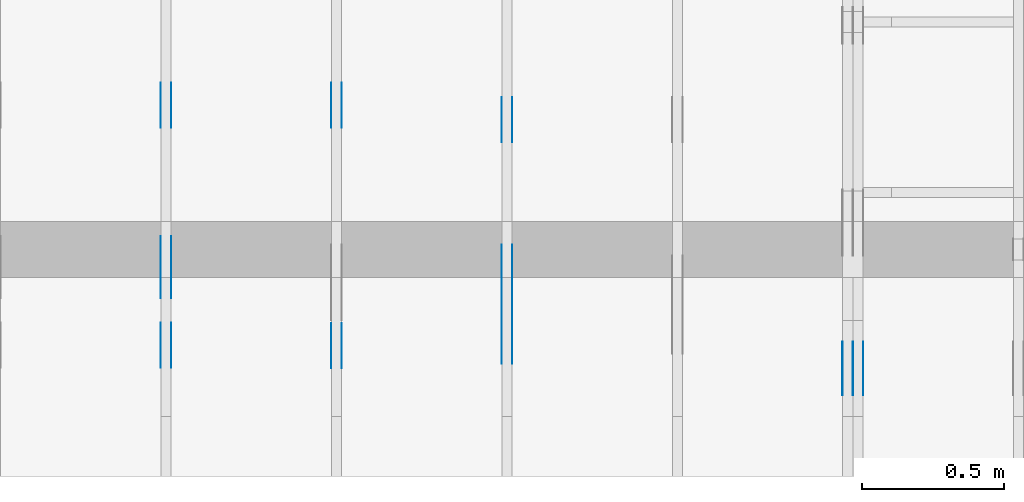
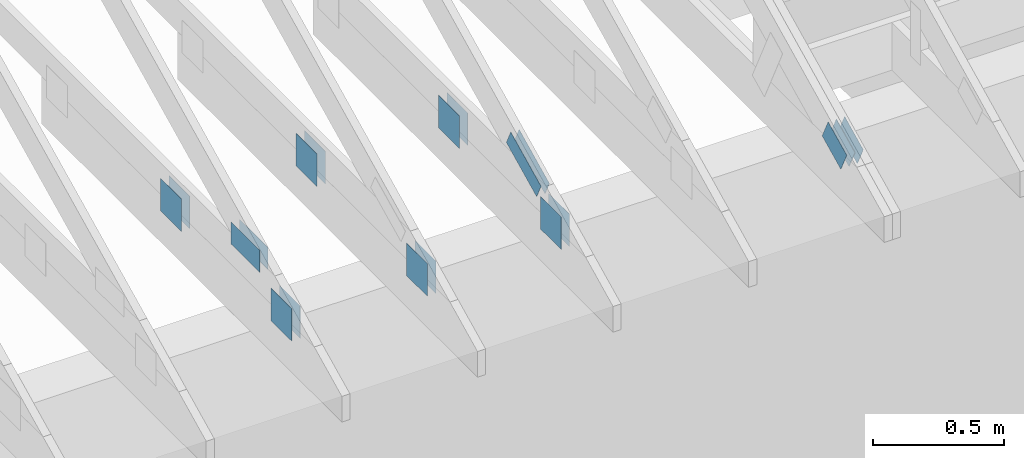
# One storey, part 112 of 159: 20 plates, 4 elements without a shape of their own.
"""IFC2X3 building model written with IfcOpenShell, lengths in millimetres."""

from ifc_helpers import new_model, si_unit, frame, origin, origin_with_axes, origin_2d, place, context, project, spatial, faceted_brep, element, aggregate, save


model = new_model("IFC2X3")

# Units and contexts
model_context = context("Model", 3, precision=1e-05, world=origin())
plan_context = context("Plan", 2, precision=1e-05, world=origin_2d())
ifc_project = project(units=[si_unit("LENGTHUNIT", "METRE", prefix="MILLI"), si_unit("AREAUNIT", "SQUARE_METRE"), si_unit("VOLUMEUNIT", "CUBIC_METRE"), si_unit("SOLIDANGLEUNIT", "STERADIAN"), si_unit("PLANEANGLEUNIT", "RADIAN"), si_unit("MASSUNIT", "GRAM"), si_unit("TIMEUNIT", "SECOND"), si_unit("THERMODYNAMICTEMPERATUREUNIT", "DEGREE_CELSIUS"), si_unit("LUMINOUSINTENSITYUNIT", "LUMEN")], contexts=[model_context, plan_context])

# Site, building, storey
site_placement = place(None, origin_with_axes())
site = spatial("IfcSite", under=ifc_project, at=site_placement, CompositionType="ELEMENT")
building_placement = place(site_placement, origin_with_axes())
building = spatial("IfcBuilding", under=site, at=building_placement, Name="Plan 1", CompositionType="ELEMENT")
storey_placement = place(building_placement, origin_with_axes())
storey = spatial("IfcBuildingStorey", under=building, at=storey_placement, Name="Etasje 1", CompositionType="ELEMENT", Elevation=0.0)

# Assembly, plates
assembly_1_placement = place(storey_placement, frame((16311.022261404749, -699.9989301294839, 1.1021457184401395e-15), z_axis=(1.0, -6.123031769111886e-17, 6.123031769111886e-17), x_axis=(6.123031769111886e-17, 1.0, 0.0)))
assembly_1 = element("IfcElementAssembly", 1, at=assembly_1_placement, inside=storey, Name="V8 (33)", AssemblyPlace="FACTORY", PredefinedType="TRUSS")
plate_1_placement = place(assembly_1_placement, frame((1227.8512822964763, 147.0, 0.0), z_axis=(0.0, 0.0, 1.0), x_axis=(1.0, 0.0, 0.0)))
plate_1 = element("IfcPlate", 2, at=plate_1_placement, Name="GNT100S 152x159", context=model_context, shape_type="Brep", body=[
    faceted_brep([(159.00003606289874, 152.0, 1.0), (3.606289874369395e-05, 152.0, 1.0), (3.606289874369395e-05, 0.0, 1.0), (159.00003606289874, 0.0, 1.0), (3.606289874369395e-05, 152.0, 4.416285493878064e-21), (159.00003606289874, 152.0, 1.947124544206129e-14), (159.00003606289874, 0.0, 1.947124544206129e-14), (3.606289874369395e-05, 0.0, 4.416285493878064e-21), (159.0, 8.234444213734565e-13, 1.788345410772899e-30), (159.0, 8.235056516911476e-13, 1.0), (1.1247455413666031e-32, 8.527125132298113e-13, 1.0), (0.0, 8.526512829121202e-13, 0.0), (159.0, 152.00000000000085, 0.0), (159.0, 152.00000000000085, 1.0), (159.0, 8.526512829121202e-13, 1.0), (159.0, 8.526512829121202e-13, 0.0), (0.0, 152.00000000000085, 0.0), (-3.7491518045553436e-33, 152.00000000000085, 1.0), (159.0, 152.00000000000085, 1.0), (159.0, 152.00000000000085, 0.0), (1.0441621786489838e-28, 8.526512829121202e-13, -6.393438191972809e-45), (6.123031769122328e-17, 8.526512829121202e-13, 1.0), (1.8675246895791357e-14, 152.00000000000085, 1.0), (1.861401657810024e-14, 152.00000000000085, -1.139742148584831e-30)], [[[0, 1, 2, 3]], [[4, 5, 6, 7]], [[8, 9, 10, 11]], [[12, 13, 14, 15]], [[16, 17, 18, 19]], [[20, 21, 22, 23]]]),
])
plate_2_placement = place(assembly_1_placement, frame((1227.8512822964763, 147.0, -37.0), z_axis=(0.0, 0.0, 1.0), x_axis=(1.0, 0.0, 0.0)))
plate_2 = element("IfcPlate", 3, at=plate_2_placement, Name="GNT100S 152x159", context=model_context, shape_type="Brep", body=[
    faceted_brep([(159.00003606289874, 152.0, 1.0), (3.606289874369395e-05, 152.0, 1.0), (3.606289874369395e-05, 0.0, 1.0), (159.00003606289874, 0.0, 1.0), (3.606289874369395e-05, 152.0, 4.416285493878064e-21), (159.00003606289874, 152.0, 1.947124544206129e-14), (159.00003606289874, 0.0, 1.947124544206129e-14), (3.606289874369395e-05, 0.0, 4.416285493878064e-21), (159.0, 8.234444213734565e-13, 1.788345410772899e-30), (159.0, 8.235056516911476e-13, 1.0), (1.1247455413666031e-32, 8.527125132298113e-13, 1.0), (0.0, 8.526512829121202e-13, 0.0), (159.0, 152.00000000000085, 0.0), (159.0, 152.00000000000085, 1.0), (159.0, 8.526512829121202e-13, 1.0), (159.0, 8.526512829121202e-13, 0.0), (0.0, 152.00000000000085, 0.0), (-3.7491518045553436e-33, 152.00000000000085, 1.0), (159.0, 152.00000000000085, 1.0), (159.0, 152.00000000000085, 0.0), (1.0441621786489838e-28, 8.526512829121202e-13, -6.393438191972809e-45), (6.123031769122328e-17, 8.526512829121202e-13, 1.0), (1.8675246895791357e-14, 152.00000000000085, 1.0), (1.861401657810024e-14, 152.00000000000085, -1.139742148584831e-30)], [[[0, 1, 2, 3]], [[4, 5, 6, 7]], [[8, 9, 10, 11]], [[12, 13, 14, 15]], [[16, 17, 18, 19]], [[20, 21, 22, 23]]]),
])
plate_3_placement = place(assembly_1_placement, frame((381.4606212335775, 147.0, 0.0), z_axis=(0.0, 0.0, 1.0), x_axis=(1.0, 0.0, 0.0)))
plate_3 = element("IfcPlate", 4, at=plate_3_placement, Name="GNT100S 152x159", context=model_context, shape_type="Brep", body=[
    faceted_brep([(159.00001109064124, 152.0, 1.0), (1.10906412373879e-05, 152.0, 1.0), (1.10906412373879e-05, 0.0, 1.0), (159.00001109064124, 0.0, 1.0), (1.10906412373879e-05, 152.0, 1.3581669727269694e-21), (159.00001109064124, 152.0, 1.9471242383942773e-14), (159.00001109064124, 0.0, 1.9471242383942773e-14), (1.10906412373879e-05, 0.0, 1.3581669727269694e-21), (159.0, 5.108056176390124e-13, 1.788345410772899e-30), (159.0, 5.108668479567036e-13, 1.0), (1.1247455413666031e-32, 5.400737094953673e-13, 1.0), (0.0, 5.400124791776761e-13, 0.0), (159.0, 152.00000000000057, 0.0), (159.0, 152.00000000000057, 1.0), (159.0, 5.400124791776761e-13, 1.0), (159.0, 5.400124791776761e-13, 0.0), (4.861730685829017e-63, 152.00000000000057, 0.0), (-3.7491518045553436e-33, 152.00000000000057, 1.0), (159.0, 152.00000000000057, 1.0), (159.0, 152.00000000000057, 0.0), (6.613027131443564e-29, 5.400124791776761e-13, -4.049177521582779e-45), (6.123031769118499e-17, 5.400124791776761e-13, 1.0), (1.8675246895791323e-14, 152.00000000000057, 1.0), (1.8614016578100204e-14, 152.00000000000057, -1.1397421485848287e-30)], [[[0, 1, 2, 3]], [[4, 5, 6, 7]], [[8, 9, 10, 11]], [[12, 13, 14, 15]], [[16, 17, 18, 19]], [[20, 21, 22, 23]]]),
])
plate_4_placement = place(assembly_1_placement, frame((381.4606212335775, 147.0, -37.0), z_axis=(0.0, 0.0, 1.0), x_axis=(1.0, 0.0, 0.0)))
plate_4 = element("IfcPlate", 5, at=plate_4_placement, Name="GNT100S 152x159", context=model_context, shape_type="Brep", body=[
    faceted_brep([(159.00001109064124, 152.0, 1.0), (1.10906412373879e-05, 152.0, 1.0), (1.10906412373879e-05, 0.0, 1.0), (159.00001109064124, 0.0, 1.0), (1.10906412373879e-05, 152.0, 1.3581669727269694e-21), (159.00001109064124, 152.0, 1.9471242383942773e-14), (159.00001109064124, 0.0, 1.9471242383942773e-14), (1.10906412373879e-05, 0.0, 1.3581669727269694e-21), (159.0, 5.108056176390124e-13, 1.788345410772899e-30), (159.0, 5.108668479567036e-13, 1.0), (1.1247455413666031e-32, 5.400737094953673e-13, 1.0), (0.0, 5.400124791776761e-13, 0.0), (159.0, 152.00000000000057, 0.0), (159.0, 152.00000000000057, 1.0), (159.0, 5.400124791776761e-13, 1.0), (159.0, 5.400124791776761e-13, 0.0), (4.861730685829017e-63, 152.00000000000057, 0.0), (-3.7491518045553436e-33, 152.00000000000057, 1.0), (159.0, 152.00000000000057, 1.0), (159.0, 152.00000000000057, 0.0), (6.613027131443564e-29, 5.400124791776761e-13, -4.049177521582779e-45), (6.123031769118499e-17, 5.400124791776761e-13, 1.0), (1.8675246895791323e-14, 152.00000000000057, 1.0), (1.8614016578100204e-14, 152.00000000000057, -1.1397421485848287e-30)], [[[0, 1, 2, 3]], [[4, 5, 6, 7]], [[8, 9, 10, 11]], [[12, 13, 14, 15]], [[16, 17, 18, 19]], [[20, 21, 22, 23]]]),
])
aggregate(assembly_1, [plate_1, plate_2, plate_3, plate_4])

assembly_2_placement = place(storey_placement, frame((18074.541652722903, -699.9989301294845, 4.408582873760558e-15), z_axis=(-1.0, 1.836909530733566e-16, 6.123031769111886e-17), x_axis=(-1.836909530733566e-16, -1.0, 0.0)))
assembly_2 = element("IfcElementAssembly", 6, at=assembly_2_placement, inside=storey, Name="V5 (30)", AssemblyPlace="FACTORY", PredefinedType="TRUSS")
plate_5_placement = place(assembly_2_placement, frame((-285.957784191883, 234.43738961878654, 0.0), z_axis=(0.0, 0.0, 1.0), x_axis=(-0.898794046299167, 0.4383711467890773, 0.0)))
plate_5 = element("IfcPlate", 7, at=plate_5_placement, Name="GNT100S 103x159", context=model_context, shape_type="Brep", body=[
    faceted_brep([(159.00000923096593, 103.00000161972872, 1.0), (3.168624004956655e-06, 103.00000161972872, 1.0), (1.0550605679782166e-05, 1.1742301637696073e-06, 1.0), (158.9999891839301, 1.1742301637696073e-06, 1.0), (3.168624004956655e-06, 103.00000161972872, 3.8803170893440275e-22), (159.00000923096593, 103.00000161972872, 1.947124215620575e-14), (158.9999891839301, 0.0, 1.9471239701233004e-14), (1.0550605679782166e-05, 0.0, 1.2920338752135702e-21), (159.0, 2.674818559636802e-06, 4.3987508537219385e-30), (159.0, 2.6748185596980325e-06, 1.0), (1.1247412067311844e-32, 2.674818588904894e-06, 1.0), (0.0, 2.6748185888436637e-06, 0.0), (159.0, 103.00000267481863, 0.0), (159.0, 103.00000267481863, 1.0), (159.0, 2.674818631476228e-06, 1.0), (159.0, 2.674818631476228e-06, 0.0), (5.6843418860808e-14, 103.00000267481859, 0.0), (5.6843418860808e-14, 103.00000267481859, 1.0), (159.0, 103.00000267481862, 1.0), (159.0, 103.00000267481862, -7.888609052210118e-31), (3.924492302574175e-23, 2.6748185888436637e-06, -2.402979104629673e-39), (6.123035693604189e-17, 2.6748185888436637e-06, 1.0), (5.841586441586298e-14, 103.00000267481859, 1.0), (5.835463409817186e-14, 103.00000267481859, -9.253218908344752e-32)], [[[0, 1, 2, 3]], [[4, 5, 6, 7]], [[8, 9, 10, 11]], [[12, 13, 14, 15]], [[16, 17, 18, 19]], [[20, 21, 22, 23]]]),
])
plate_6_placement = place(assembly_2_placement, frame((-285.957784191883, 234.43738961878654, -37.0), z_axis=(0.0, 0.0, 1.0), x_axis=(-0.898794046299167, 0.4383711467890773, 0.0)))
plate_6 = element("IfcPlate", 8, at=plate_6_placement, Name="GNT100S 103x159", context=model_context, shape_type="Brep", body=[
    faceted_brep([(159.00000923096593, 103.00000161972872, 1.0), (3.168624004956655e-06, 103.00000161972872, 1.0), (1.0550605679782166e-05, 1.1742301637696073e-06, 1.0), (158.9999891839301, 1.1742301637696073e-06, 1.0), (3.168624004956655e-06, 103.00000161972872, 3.8803170893440275e-22), (159.00000923096593, 103.00000161972872, 1.947124215620575e-14), (158.9999891839301, 0.0, 1.9471239701233004e-14), (1.0550605679782166e-05, 0.0, 1.2920338752135702e-21), (159.0, 2.674818559636802e-06, 4.3987508537219385e-30), (159.0, 2.6748185596980325e-06, 1.0), (1.1247412067311844e-32, 2.674818588904894e-06, 1.0), (0.0, 2.6748185888436637e-06, 0.0), (159.0, 103.00000267481863, 0.0), (159.0, 103.00000267481863, 1.0), (159.0, 2.674818631476228e-06, 1.0), (159.0, 2.674818631476228e-06, 0.0), (5.6843418860808e-14, 103.00000267481859, 0.0), (5.6843418860808e-14, 103.00000267481859, 1.0), (159.0, 103.00000267481862, 1.0), (159.0, 103.00000267481862, -7.888609052210118e-31), (3.924492302574175e-23, 2.6748185888436637e-06, -2.402979104629673e-39), (6.123035693604189e-17, 2.6748185888436637e-06, 1.0), (5.841586441586298e-14, 103.00000267481859, 1.0), (5.835463409817186e-14, 103.00000267481859, -9.253218908344752e-32)], [[[0, 1, 2, 3]], [[4, 5, 6, 7]], [[8, 9, 10, 11]], [[12, 13, 14, 15]], [[16, 17, 18, 19]], [[20, 21, 22, 23]]]),
])
plate_7_placement = place(assembly_2_placement, frame((-285.957784191883, 234.43738961878654, -36.0), z_axis=(0.0, 0.0, 1.0), x_axis=(-0.898794046299167, 0.4383711467890773, 0.0)))
plate_7 = element("IfcPlate", 9, at=plate_7_placement, Name="GNT100S 103x159", context=model_context, shape_type="Brep", body=[
    faceted_brep([(159.00000923096593, 103.00000161972872, 1.0), (3.168624004956655e-06, 103.00000161972872, 1.0), (1.0550605679782166e-05, 1.1742301637696073e-06, 1.0), (158.9999891839301, 1.1742301637696073e-06, 1.0), (3.168624004956655e-06, 103.00000161972872, 3.8803170893440275e-22), (159.00000923096593, 103.00000161972872, 1.947124215620575e-14), (158.9999891839301, 0.0, 1.9471239701233004e-14), (1.0550605679782166e-05, 0.0, 1.2920338752135702e-21), (159.0, 2.674818559636802e-06, 4.3987508537219385e-30), (159.0, 2.6748185596980325e-06, 1.0), (1.1247412067311844e-32, 2.674818588904894e-06, 1.0), (0.0, 2.6748185888436637e-06, 0.0), (159.0, 103.00000267481863, 0.0), (159.0, 103.00000267481863, 1.0), (159.0, 2.674818631476228e-06, 1.0), (159.0, 2.674818631476228e-06, 0.0), (5.6843418860808e-14, 103.00000267481859, 0.0), (5.6843418860808e-14, 103.00000267481859, 1.0), (159.0, 103.00000267481862, 1.0), (159.0, 103.00000267481862, -7.888609052210118e-31), (3.924492302574175e-23, 2.6748185888436637e-06, -2.402979104629673e-39), (6.123035693604189e-17, 2.6748185888436637e-06, 1.0), (5.841586441586298e-14, 103.00000267481859, 1.0), (5.835463409817186e-14, 103.00000267481859, -9.253218908344752e-32)], [[[0, 1, 2, 3]], [[4, 5, 6, 7]], [[8, 9, 10, 11]], [[12, 13, 14, 15]], [[16, 17, 18, 19]], [[20, 21, 22, 23]]]),
])
plate_8_placement = place(assembly_2_placement, frame((-285.957784191883, 234.43738961878654, -73.0), z_axis=(0.0, 0.0, 1.0), x_axis=(-0.898794046299167, 0.4383711467890773, 0.0)))
plate_8 = element("IfcPlate", 10, at=plate_8_placement, Name="GNT100S 103x159", context=model_context, shape_type="Brep", body=[
    faceted_brep([(159.00000923096593, 103.00000161972872, 1.0), (3.168624004956655e-06, 103.00000161972872, 1.0), (1.0550605679782166e-05, 1.1742301637696073e-06, 1.0), (158.9999891839301, 1.1742301637696073e-06, 1.0), (3.168624004956655e-06, 103.00000161972872, 3.8803170893440275e-22), (159.00000923096593, 103.00000161972872, 1.947124215620575e-14), (158.9999891839301, 0.0, 1.9471239701233004e-14), (1.0550605679782166e-05, 0.0, 1.2920338752135702e-21), (159.0, 2.674818559636802e-06, 4.3987508537219385e-30), (159.0, 2.6748185596980325e-06, 1.0), (1.1247412067311844e-32, 2.674818588904894e-06, 1.0), (0.0, 2.6748185888436637e-06, 0.0), (159.0, 103.00000267481863, 0.0), (159.0, 103.00000267481863, 1.0), (159.0, 2.674818631476228e-06, 1.0), (159.0, 2.674818631476228e-06, 0.0), (5.6843418860808e-14, 103.00000267481859, 0.0), (5.6843418860808e-14, 103.00000267481859, 1.0), (159.0, 103.00000267481862, 1.0), (159.0, 103.00000267481862, -7.888609052210118e-31), (3.924492302574175e-23, 2.6748185888436637e-06, -2.402979104629673e-39), (6.123035693604189e-17, 2.6748185888436637e-06, 1.0), (5.841586441586298e-14, 103.00000267481859, 1.0), (5.835463409817186e-14, 103.00000267481859, -9.253218908344752e-32)], [[[0, 1, 2, 3]], [[4, 5, 6, 7]], [[8, 9, 10, 11]], [[12, 13, 14, 15]], [[16, 17, 18, 19]], [[20, 21, 22, 23]]]),
])
aggregate(assembly_2, [plate_5, plate_6, plate_7, plate_8])

assembly_3_placement = place(storey_placement, frame((16875.02226140475, -699.9989301294827, 1.1021457184401395e-15), z_axis=(-1.0, 1.836909530733566e-16, 6.123031769111886e-17), x_axis=(-1.836909530733566e-16, -1.0, 0.0)))
assembly_3 = element("IfcElementAssembly", 11, at=assembly_3_placement, inside=storey, Name="V7 (32)", AssemblyPlace="FACTORY", PredefinedType="TRUSS")
plate_9_placement = place(assembly_3_placement, frame((-550.8304443359375, 348.60430908203125, 0.0), z_axis=(0.0, 0.0, 1.0), x_axis=(-0.898794046299167, 0.4383711467890773, 0.0)))
plate_9 = element("IfcPlate", 12, at=plate_9_placement, Name="GNT100S 76x258", context=model_context, shape_type="Brep", body=[
    faceted_brep([(257.99999468874285, 76.00000888797729, 1.0), (1.3453948326969112e-05, 76.00000888797729, 1.0), (0.0, 0.0, 1.0), (257.9999812347945, 0.0, 1.0), (1.3453948326969112e-05, 76.00000888797729, 1.6475790605204317e-21), (257.99999468874285, 76.00000888797729, 3.159484327819741e-14), (257.9999812347945, 1.8024312566922163e-05, 3.159484163061835e-14), (0.0, 1.8024312566922163e-05, 0.0), (258.00000746283956, 1.8391251482300188e-05, 4.64211389586053e-30), (258.00000746283956, 1.839125148236142e-05, 1.0), (7.462839562322188e-06, 1.8391251529753684e-05, 1.0), (7.462839562322188e-06, 1.8391251529692454e-05, 0.0), (258.00000746283956, 76.00001839125156, 0.0), (258.00000746283956, 76.00001839125156, 1.0), (258.00000746283956, 1.8391251558114163e-05, 1.0), (258.00000746283956, 1.8391251558114163e-05, 0.0), (7.462839562322188e-06, 76.0000183912515, 0.0), (7.462839562322188e-06, 76.0000183912515, 1.0), (258.00000746283956, 76.00001839125154, 1.0), (258.00000746283956, 76.00001839125154, -1.5777218104420236e-30), (7.46283956232219e-06, 1.8391251529692454e-05, -9.4039548065783e-38), (7.4628395623834206e-06, 1.8391251529692454e-05, 1.0), (7.462839571690429e-06, 76.0000183912515, 1.0), (7.4628395716291985e-06, 76.0000183912515, -5.698711977193191e-31)], [[[0, 1, 2, 3]], [[4, 5, 6, 7]], [[8, 9, 10, 11]], [[12, 13, 14, 15]], [[16, 17, 18, 19]], [[20, 21, 22, 23]]]),
])
plate_10_placement = place(assembly_3_placement, frame((-550.8304443359375, 348.60430908203125, -37.0), z_axis=(0.0, 0.0, 1.0), x_axis=(-0.898794046299167, 0.4383711467890773, 0.0)))
plate_10 = element("IfcPlate", 13, at=plate_10_placement, Name="GNT100S 76x258", context=model_context, shape_type="Brep", body=[
    faceted_brep([(257.99999468874285, 76.00000888797729, 1.0), (1.3453948326969112e-05, 76.00000888797729, 1.0), (0.0, 0.0, 1.0), (257.9999812347945, 0.0, 1.0), (1.3453948326969112e-05, 76.00000888797729, 1.6475790605204317e-21), (257.99999468874285, 76.00000888797729, 3.159484327819741e-14), (257.9999812347945, 1.8024312566922163e-05, 3.159484163061835e-14), (0.0, 1.8024312566922163e-05, 0.0), (258.00000746283956, 1.8391251482300188e-05, 4.64211389586053e-30), (258.00000746283956, 1.839125148236142e-05, 1.0), (7.462839562322188e-06, 1.8391251529753684e-05, 1.0), (7.462839562322188e-06, 1.8391251529692454e-05, 0.0), (258.00000746283956, 76.00001839125156, 0.0), (258.00000746283956, 76.00001839125156, 1.0), (258.00000746283956, 1.8391251558114163e-05, 1.0), (258.00000746283956, 1.8391251558114163e-05, 0.0), (7.462839562322188e-06, 76.0000183912515, 0.0), (7.462839562322188e-06, 76.0000183912515, 1.0), (258.00000746283956, 76.00001839125154, 1.0), (258.00000746283956, 76.00001839125154, -1.5777218104420236e-30), (7.46283956232219e-06, 1.8391251529692454e-05, -9.4039548065783e-38), (7.4628395623834206e-06, 1.8391251529692454e-05, 1.0), (7.462839571690429e-06, 76.0000183912515, 1.0), (7.4628395716291985e-06, 76.0000183912515, -5.698711977193191e-31)], [[[0, 1, 2, 3]], [[4, 5, 6, 7]], [[8, 9, 10, 11]], [[12, 13, 14, 15]], [[16, 17, 18, 19]], [[20, 21, 22, 23]]]),
])
plate_11_placement = place(assembly_3_placement, frame((-1335.0917177118827, 146.99999999999977, 0.0), z_axis=(0.0, 0.0, 1.0), x_axis=(1.0, 0.0, 0.0)))
plate_11 = element("IfcPlate", 14, at=plate_11_placement, Name="GNT100S 152x159", context=model_context, shape_type="Brep", body=[
    faceted_brep([(159.00004290719517, 152.00000000000023, 1.0), (4.2907195165753365e-05, 152.00000000000023, 1.0), (4.2907195165753365e-05, 2.2737367544323206e-13, 1.0), (159.00004290719517, 2.2737367544323206e-13, 1.0), (4.2907195165753365e-05, 152.00000000000023, 5.254442382467836e-21), (159.00004290719517, 152.00000000000023, 1.947124628021818e-14), (159.00004290719517, 2.2737367544323206e-13, 1.947124628021818e-14), (4.2907195165753365e-05, 2.2737367544323206e-13, 5.254442382467836e-21), (159.0, -2.92068615386637e-14, 1.788345410772899e-30), (159.0, -2.914563122097258e-14, 1.0), (1.1247455413666031e-32, 6.123031769111886e-17, 1.0), (0.0, 0.0, 0.0), (159.0, 152.0, 0.0), (159.0, 152.0, 1.0), (159.0, 0.0, 1.0), (159.0, 0.0, 0.0), (0.0, 152.0, 0.0), (-3.7491518045553436e-33, 152.0, 1.0), (159.0, 152.0, 1.0), (159.0, 152.0, 0.0), (0.0, 0.0, 0.0), (6.123031769111886e-17, -7.498303609110687e-33, 1.0), (1.8675246895791253e-14, 152.0, 1.0), (1.8614016578100134e-14, 152.0, -1.1397421485848245e-30)], [[[0, 1, 2, 3]], [[4, 5, 6, 7]], [[8, 9, 10, 11]], [[12, 13, 14, 15]], [[16, 17, 18, 19]], [[20, 21, 22, 23]]]),
])
plate_12_placement = place(assembly_3_placement, frame((-1335.0917177118827, 146.99999999999977, -37.0), z_axis=(0.0, 0.0, 1.0), x_axis=(1.0, 0.0, 0.0)))
plate_12 = element("IfcPlate", 15, at=plate_12_placement, Name="GNT100S 152x159", context=model_context, shape_type="Brep", body=[
    faceted_brep([(159.00004290719517, 152.00000000000023, 1.0), (4.2907195165753365e-05, 152.00000000000023, 1.0), (4.2907195165753365e-05, 2.2737367544323206e-13, 1.0), (159.00004290719517, 2.2737367544323206e-13, 1.0), (4.2907195165753365e-05, 152.00000000000023, 5.254442382467836e-21), (159.00004290719517, 152.00000000000023, 1.947124628021818e-14), (159.00004290719517, 2.2737367544323206e-13, 1.947124628021818e-14), (4.2907195165753365e-05, 2.2737367544323206e-13, 5.254442382467836e-21), (159.0, -2.92068615386637e-14, 1.788345410772899e-30), (159.0, -2.914563122097258e-14, 1.0), (1.1247455413666031e-32, 6.123031769111886e-17, 1.0), (0.0, 0.0, 0.0), (159.0, 152.0, 0.0), (159.0, 152.0, 1.0), (159.0, 0.0, 1.0), (159.0, 0.0, 0.0), (0.0, 152.0, 0.0), (-3.7491518045553436e-33, 152.0, 1.0), (159.0, 152.0, 1.0), (159.0, 152.0, 0.0), (0.0, 0.0, 0.0), (6.123031769111886e-17, -7.498303609110687e-33, 1.0), (1.8675246895791253e-14, 152.0, 1.0), (1.8614016578100134e-14, 152.0, -1.1397421485848245e-30)], [[[0, 1, 2, 3]], [[4, 5, 6, 7]], [[8, 9, 10, 11]], [[12, 13, 14, 15]], [[16, 17, 18, 19]], [[20, 21, 22, 23]]]),
])
plate_13_placement = place(assembly_3_placement, frame((-396.8488694594707, 299.0, 0.0), z_axis=(0.0, 0.0, 1.0), x_axis=(-1.0, 1.2246063538223773e-16, 0.0)))
plate_13 = element("IfcPlate", 16, at=plate_13_placement, Name="GNT100S 152x159", context=model_context, shape_type="Brep", body=[
    faceted_brep([(159.00000749365427, 152.0, 1.0), (7.493654265999794e-06, 152.0, 1.0), (7.493654322843213e-06, 0.0, 1.0), (159.00000749365427, 0.0, 1.0), (7.493654265999794e-06, 152.0, 9.17677662749151e-22), (159.00000749365427, 152.0, 1.947124194345346e-14), (159.00000749365427, 0.0, 1.947124194345346e-14), (7.493654322843213e-06, 0.0, 9.176776697102322e-22), (159.0, 1.9816681390456836e-13, 1.788345410772899e-30), (159.0, 1.9822804422225948e-13, 1.0), (5.684341886080802e-14, 2.274349057609232e-13, 1.0), (5.684341886080802e-14, 2.2737367544323206e-13, 0.0), (159.0, 152.00000000000023, 0.0), (159.0, 152.00000000000023, 1.0), (159.0, 2.2737367544323206e-13, 1.0), (159.0, 2.2737367544323206e-13, 0.0), (0.0, 152.00000000000023, 0.0), (-3.7491518045553436e-33, 152.00000000000023, 1.0), (159.0, 152.00000000000023, 1.0), (159.0, 152.00000000000023, 0.0), (5.684341886080802e-14, 2.2737367544323206e-13, -7.006492321624085e-46), (5.690464917849913e-14, 2.2737367544323206e-13, 1.0), (8.01710585938975e-15, 152.00000000000023, 1.0), (7.955875541698632e-15, 152.00000000000023, -4.871407869292099e-31)], [[[0, 1, 2, 3]], [[4, 5, 6, 7]], [[8, 9, 10, 11]], [[12, 13, 14, 15]], [[16, 17, 18, 19]], [[20, 21, 22, 23]]]),
])
plate_14_placement = place(assembly_3_placement, frame((-396.8488694594707, 299.0, -37.0), z_axis=(0.0, 0.0, 1.0), x_axis=(-1.0, 1.2246063538223773e-16, 0.0)))
plate_14 = element("IfcPlate", 17, at=plate_14_placement, Name="GNT100S 152x159", context=model_context, shape_type="Brep", body=[
    faceted_brep([(159.00000749365427, 152.0, 1.0), (7.493654265999794e-06, 152.0, 1.0), (7.493654322843213e-06, 0.0, 1.0), (159.00000749365427, 0.0, 1.0), (7.493654265999794e-06, 152.0, 9.17677662749151e-22), (159.00000749365427, 152.0, 1.947124194345346e-14), (159.00000749365427, 0.0, 1.947124194345346e-14), (7.493654322843213e-06, 0.0, 9.176776697102322e-22), (159.0, 1.9816681390456836e-13, 1.788345410772899e-30), (159.0, 1.9822804422225948e-13, 1.0), (5.684341886080802e-14, 2.274349057609232e-13, 1.0), (5.684341886080802e-14, 2.2737367544323206e-13, 0.0), (159.0, 152.00000000000023, 0.0), (159.0, 152.00000000000023, 1.0), (159.0, 2.2737367544323206e-13, 1.0), (159.0, 2.2737367544323206e-13, 0.0), (0.0, 152.00000000000023, 0.0), (-3.7491518045553436e-33, 152.00000000000023, 1.0), (159.0, 152.00000000000023, 1.0), (159.0, 152.00000000000023, 0.0), (5.684341886080802e-14, 2.2737367544323206e-13, -7.006492321624085e-46), (5.690464917849913e-14, 2.2737367544323206e-13, 1.0), (8.01710585938975e-15, 152.00000000000023, 1.0), (7.955875541698632e-15, 152.00000000000023, -4.871407869292099e-31)], [[[0, 1, 2, 3]], [[4, 5, 6, 7]], [[8, 9, 10, 11]], [[12, 13, 14, 15]], [[16, 17, 18, 19]], [[20, 21, 22, 23]]]),
])
aggregate(assembly_3, [plate_9, plate_10, plate_11, plate_12, plate_13, plate_14])

assembly_4_placement = place(storey_placement, frame((15675.02226140475, -699.9989301294845, 1.1021457184401395e-15), z_axis=(-1.0, 1.836909530733566e-16, 6.123031769111886e-17), x_axis=(-1.836909530733566e-16, -1.0, 0.0)))
assembly_4 = element("IfcElementAssembly", 18, at=assembly_4_placement, inside=storey, Name="T7 (111)", AssemblyPlace="FACTORY", PredefinedType="TRUSS")
plate_15_placement = place(assembly_4_placement, frame((-628.6262642387301, 422.5000000000001, 0.0), z_axis=(0.0, 0.0, 1.0), x_axis=(-1.0, 1.2246063538223773e-16, 0.0)))
plate_15 = element("IfcPlate", 19, at=plate_15_placement, Name="GNT100S 103x218", context=model_context, shape_type="Brep", body=[
    faceted_brep([(218.00001749955118, 103.00000000000011, 1.0), (1.749955117702484e-05, 103.00000000000011, 1.0), (1.749955117702484e-05, 1.1368683772161603e-13, 1.0), (218.00001749955118, 1.1368683772161603e-13, 1.0), (1.749955117702484e-05, 103.00000000000011, 2.143006156042448e-21), (218.00001749955118, 103.00000000000011, 2.669642065633398e-14), (218.00001749955118, 1.7053025658242404e-13, 2.669642065633398e-14), (1.749955117702484e-05, 1.7053025658242404e-13, 2.143006156042448e-21), (218.0, -4.0044627769991736e-14, 5.932485875675807e-30), (218.0, -3.998339745230062e-14, 1.0), (1.1247455413666031e-32, 6.123031769111886e-17, 1.0), (0.0, 0.0, 0.0), (218.0, 103.00000000000006, 0.0), (218.0, 103.00000000000006, 1.0), (218.0, 5.684341886080802e-14, 1.0), (218.0, 5.684341886080802e-14, 0.0), (0.0, 103.0, 0.0), (0.0, 103.0, 1.0), (218.0, 103.00000000000003, 1.0), (218.0, 103.00000000000003, -7.888609052210118e-31), (0.0, 0.0, 0.0), (6.123031769111886e-17, -7.498303609110687e-33, 1.0), (1.2674675762061605e-14, 103.0, 1.0), (1.2613445444370486e-14, 103.0, -7.723252717384008e-31)], [[[0, 1, 2, 3]], [[4, 5, 6, 7]], [[8, 9, 10, 11]], [[12, 13, 14, 15]], [[16, 17, 18, 19]], [[20, 21, 22, 23]]]),
])
plate_16_placement = place(assembly_4_placement, frame((-628.6262642387301, 422.5000000000001, -37.0), z_axis=(0.0, 0.0, 1.0), x_axis=(-1.0, 1.2246063538223773e-16, 0.0)))
plate_16 = element("IfcPlate", 20, at=plate_16_placement, Name="GNT100S 103x218", context=model_context, shape_type="Brep", body=[
    faceted_brep([(218.00001749955118, 103.00000000000011, 1.0), (1.749955117702484e-05, 103.00000000000011, 1.0), (1.749955117702484e-05, 1.1368683772161603e-13, 1.0), (218.00001749955118, 1.1368683772161603e-13, 1.0), (1.749955117702484e-05, 103.00000000000011, 2.143006156042448e-21), (218.00001749955118, 103.00000000000011, 2.669642065633398e-14), (218.00001749955118, 1.7053025658242404e-13, 2.669642065633398e-14), (1.749955117702484e-05, 1.7053025658242404e-13, 2.143006156042448e-21), (218.0, -4.0044627769991736e-14, 5.932485875675807e-30), (218.0, -3.998339745230062e-14, 1.0), (1.1247455413666031e-32, 6.123031769111886e-17, 1.0), (0.0, 0.0, 0.0), (218.0, 103.00000000000006, 0.0), (218.0, 103.00000000000006, 1.0), (218.0, 5.684341886080802e-14, 1.0), (218.0, 5.684341886080802e-14, 0.0), (0.0, 103.0, 0.0), (0.0, 103.0, 1.0), (218.0, 103.00000000000003, 1.0), (218.0, 103.00000000000003, -7.888609052210118e-31), (0.0, 0.0, 0.0), (6.123031769111886e-17, -7.498303609110687e-33, 1.0), (1.2674675762061605e-14, 103.0, 1.0), (1.2613445444370486e-14, 103.0, -7.723252717384008e-31)], [[[0, 1, 2, 3]], [[4, 5, 6, 7]], [[8, 9, 10, 11]], [[12, 13, 14, 15]], [[16, 17, 18, 19]], [[20, 21, 22, 23]]]),
])
plate_17_placement = place(assembly_4_placement, frame((-1386.8507473616942, 146.99999999999986, 0.0), z_axis=(0.0, 0.0, 1.0), x_axis=(1.0, 0.0, 0.0)))
plate_17 = element("IfcPlate", 21, at=plate_17_placement, Name="GNT100S 152x159", context=model_context, shape_type="Brep", body=[
    faceted_brep([(159.00003935388168, 152.00000000000014, 1.0), (3.9353881675197044e-05, 152.00000000000014, 1.0), (3.9353881675197044e-05, 1.4210854715202004e-13, 1.0), (159.00003935388168, 1.4210854715202004e-13, 1.0), (3.9353881675197044e-05, 152.00000000000014, 4.819301354702032e-21), (159.00003935388168, 152.00000000000014, 1.9471245845077154e-14), (159.00003935388168, 1.4210854715202004e-13, 1.9471245845077154e-14), (3.9353881675197044e-05, 1.4210854715202004e-13, 4.819301354702032e-21), (159.0, -2.92068615386637e-14, 1.788345410772899e-30), (159.0, -2.914563122097258e-14, 1.0), (1.1247455413666031e-32, 6.123031769111886e-17, 1.0), (0.0, 0.0, 0.0), (159.0, 152.00000000000003, 0.0), (159.0, 152.00000000000003, 1.0), (159.0, 0.0, 1.0), (159.0, 0.0, 0.0), (0.0, 152.00000000000003, 0.0), (-3.7491518045553436e-33, 152.00000000000003, 1.0), (159.0, 152.00000000000003, 1.0), (159.0, 152.00000000000003, 0.0), (0.0, 0.0, 0.0), (6.123031769111886e-17, -7.498303609110687e-33, 1.0), (1.8675246895791256e-14, 152.00000000000003, 1.0), (1.8614016578100137e-14, 152.00000000000003, -1.1397421485848246e-30)], [[[0, 1, 2, 3]], [[4, 5, 6, 7]], [[8, 9, 10, 11]], [[12, 13, 14, 15]], [[16, 17, 18, 19]], [[20, 21, 22, 23]]]),
])
plate_18_placement = place(assembly_4_placement, frame((-1386.8507473616942, 146.99999999999986, -37.0), z_axis=(0.0, 0.0, 1.0), x_axis=(1.0, 0.0, 0.0)))
plate_18 = element("IfcPlate", 22, at=plate_18_placement, Name="GNT100S 152x159", context=model_context, shape_type="Brep", body=[
    faceted_brep([(159.00003935388168, 152.00000000000014, 1.0), (3.9353881675197044e-05, 152.00000000000014, 1.0), (3.9353881675197044e-05, 1.4210854715202004e-13, 1.0), (159.00003935388168, 1.4210854715202004e-13, 1.0), (3.9353881675197044e-05, 152.00000000000014, 4.819301354702032e-21), (159.00003935388168, 152.00000000000014, 1.9471245845077154e-14), (159.00003935388168, 1.4210854715202004e-13, 1.9471245845077154e-14), (3.9353881675197044e-05, 1.4210854715202004e-13, 4.819301354702032e-21), (159.0, -2.92068615386637e-14, 1.788345410772899e-30), (159.0, -2.914563122097258e-14, 1.0), (1.1247455413666031e-32, 6.123031769111886e-17, 1.0), (0.0, 0.0, 0.0), (159.0, 152.00000000000003, 0.0), (159.0, 152.00000000000003, 1.0), (159.0, 0.0, 1.0), (159.0, 0.0, 0.0), (0.0, 152.00000000000003, 0.0), (-3.7491518045553436e-33, 152.00000000000003, 1.0), (159.0, 152.00000000000003, 1.0), (159.0, 152.00000000000003, 0.0), (0.0, 0.0, 0.0), (6.123031769111886e-17, -7.498303609110687e-33, 1.0), (1.8675246895791256e-14, 152.00000000000003, 1.0), (1.8614016578100137e-14, 152.00000000000003, -1.1397421485848246e-30)], [[[0, 1, 2, 3]], [[4, 5, 6, 7]], [[8, 9, 10, 11]], [[12, 13, 14, 15]], [[16, 17, 18, 19]], [[20, 21, 22, 23]]]),
])
plate_19_placement = place(assembly_4_placement, frame((-382.4755138126829, 299.0, 0.0), z_axis=(0.0, 0.0, 1.0), x_axis=(-1.0, 1.2246063538223773e-16, 0.0)))
plate_19 = element("IfcPlate", 23, at=plate_19_placement, Name="GNT100S 152x159", context=model_context, shape_type="Brep", body=[
    faceted_brep([(159.0000110896608, 152.0, 1.0), (1.1089660802099388e-05, 152.0, 1.0), (1.1089660858942807e-05, 0.0, 1.0), (159.0000110896608, 0.0, 1.0), (1.1089660802099388e-05, 152.0, 1.3580469079985871e-21), (159.0000110896608, 152.0, 1.9471242383822708e-14), (159.0000110896608, 0.0, 1.9471242383822708e-14), (1.1089660858942807e-05, 0.0, 1.3580469149596683e-21), (159.0, 8.447997618295233e-14, 1.788345410772899e-30), (159.0, 8.454120650064345e-14, 1.0), (5.684341886080802e-14, 1.1374806803930715e-13, 1.0), (5.684341886080802e-14, 1.1368683772161602e-13, 0.0), (159.0, 152.0000000000001, 0.0), (159.0, 152.0000000000001, 1.0), (159.0, 1.1368683772161603e-13, 1.0), (159.0, 1.1368683772161603e-13, 0.0), (4.861730685829017e-63, 152.0000000000001, 0.0), (-3.7491518045553436e-33, 152.0000000000001, 1.0), (159.0, 152.0000000000001, 1.0), (159.0, 152.0000000000001, 0.0), (5.684341886080802e-14, 1.1368683772161603e-13, 0.0), (5.690464917849913e-14, 1.1368683772161603e-13, 1.0), (8.01710585938975e-15, 152.0000000000001, 1.0), (7.955875541698632e-15, 152.0000000000001, -4.871407869292096e-31)], [[[0, 1, 2, 3]], [[4, 5, 6, 7]], [[8, 9, 10, 11]], [[12, 13, 14, 15]], [[16, 17, 18, 19]], [[20, 21, 22, 23]]]),
])
plate_20_placement = place(assembly_4_placement, frame((-382.4755138126829, 299.0, -37.0), z_axis=(0.0, 0.0, 1.0), x_axis=(-1.0, 1.2246063538223773e-16, 0.0)))
plate_20 = element("IfcPlate", 24, at=plate_20_placement, Name="GNT100S 152x159", context=model_context, shape_type="Brep", body=[
    faceted_brep([(159.0000110896608, 152.0, 1.0), (1.1089660802099388e-05, 152.0, 1.0), (1.1089660858942807e-05, 0.0, 1.0), (159.0000110896608, 0.0, 1.0), (1.1089660802099388e-05, 152.0, 1.3580469079985871e-21), (159.0000110896608, 152.0, 1.9471242383822708e-14), (159.0000110896608, 0.0, 1.9471242383822708e-14), (1.1089660858942807e-05, 0.0, 1.3580469149596683e-21), (159.0, 8.447997618295233e-14, 1.788345410772899e-30), (159.0, 8.454120650064345e-14, 1.0), (5.684341886080802e-14, 1.1374806803930715e-13, 1.0), (5.684341886080802e-14, 1.1368683772161602e-13, 0.0), (159.0, 152.0000000000001, 0.0), (159.0, 152.0000000000001, 1.0), (159.0, 1.1368683772161603e-13, 1.0), (159.0, 1.1368683772161603e-13, 0.0), (4.861730685829017e-63, 152.0000000000001, 0.0), (-3.7491518045553436e-33, 152.0000000000001, 1.0), (159.0, 152.0000000000001, 1.0), (159.0, 152.0000000000001, 0.0), (5.684341886080802e-14, 1.1368683772161603e-13, 0.0), (5.690464917849913e-14, 1.1368683772161603e-13, 1.0), (8.01710585938975e-15, 152.0000000000001, 1.0), (7.955875541698632e-15, 152.0000000000001, -4.871407869292096e-31)], [[[0, 1, 2, 3]], [[4, 5, 6, 7]], [[8, 9, 10, 11]], [[12, 13, 14, 15]], [[16, 17, 18, 19]], [[20, 21, 22, 23]]]),
])
aggregate(assembly_4, [plate_15, plate_16, plate_17, plate_18, plate_19, plate_20])

save(model, "model.ifc")
